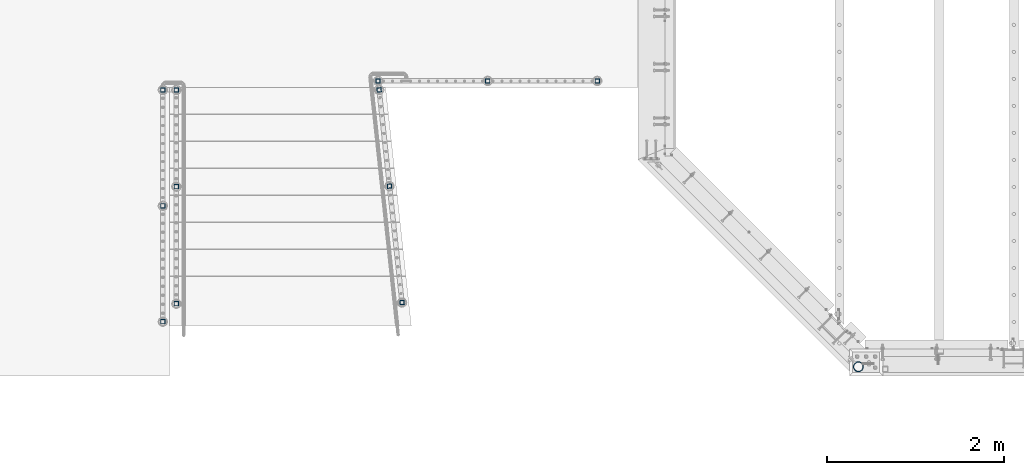
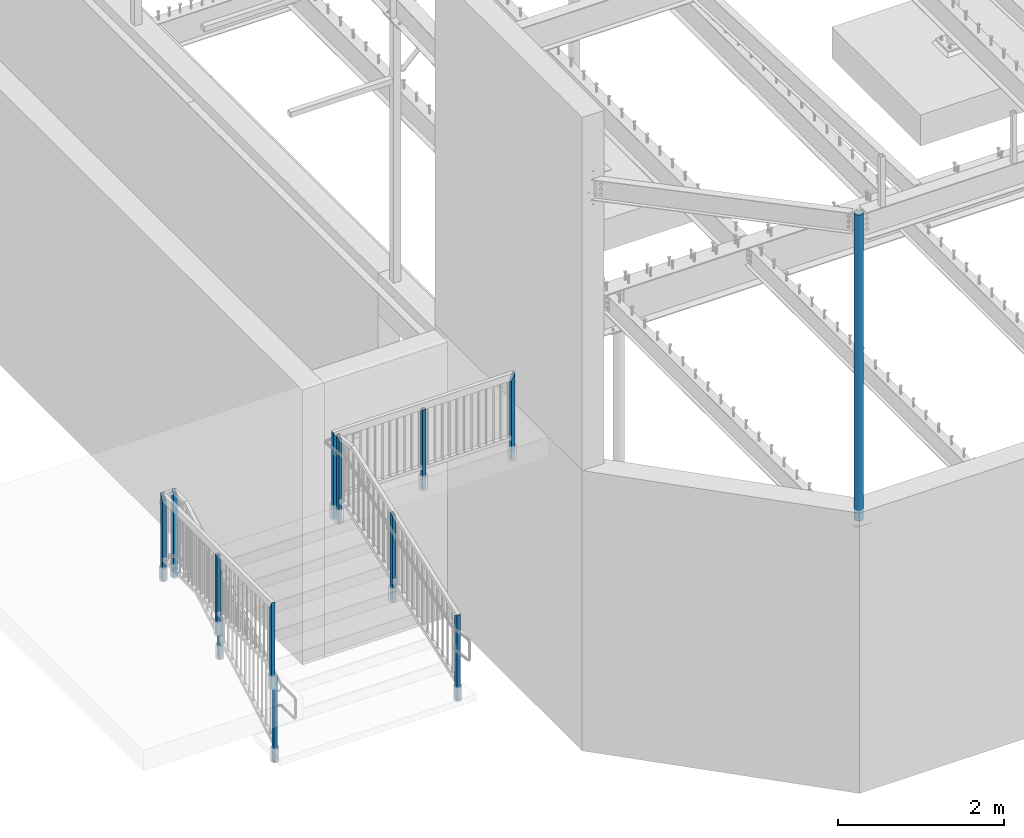
# One storey, part 120 of 975: 13 columns.
"""IFC2X3 building model written with IfcOpenShell, lengths in millimetres."""

import ifcopenshell
import ifcopenshell.guid

model = None  # the IFC model being written
_history = None  # IfcOwnerHistory: only IFC2X3 demands one
_inside = {}  # id of a spatial element -> (the spatial element, [elements in it])
_under = {}  # id of a project, library or spatial element -> (it, [spatial elements below it])
_declared = {}  # id of a project -> (the project, [libraries it declares])
_typed = {}  # id of a type object -> (the type object, [elements of that type])
_made_of = {}  # id of a material, layer set ... -> (it, [elements and type objects made of it])


def new_model(schema):
    """Start an empty IFC model of exactly this schema.

    Asked for "IFC4X3", IfcOpenShell would pick the latest addendum, in which some entities
    have other attributes; the version numbers below select the first issue.
    IFC2X3 requires an IfcOwnerHistory on every rooted entity: one is made here for all.
    """
    global model, _history
    if schema == "IFC4X3":
        model = ifcopenshell.file(schema_version=(4, 3, 0, 0))
    else:
        model = ifcopenshell.file(schema=schema)
    _inside.clear()
    _under.clear()
    _declared.clear()
    _typed.clear()
    _made_of.clear()
    _history = None
    if model.schema == "IFC2X3":
        org = make("IfcOrganization", Name="unknown")
        user = make(
            "IfcPersonAndOrganization",
            ThePerson=make("IfcPerson", FamilyName="unknown"),
            TheOrganization=org,
        )
        app = make(
            "IfcApplication",
            ApplicationDeveloper=org,
            Version="unknown",
            ApplicationFullName="unknown",
            ApplicationIdentifier="unknown",
        )
        _history = make(
            "IfcOwnerHistory",
            OwningUser=user,
            OwningApplication=app,
            ChangeAction="ADDED",
            CreationDate=0,
        )
    return model


def make(cls, **values):
    """One entity of the class cls with the attributes given. An attribute that is None is left unset."""
    return model.create_entity(
        cls, **{name: value for name, value in values.items() if value is not None}
    )


def rooted(cls, **values):
    """An entity with a GlobalId (a new one), such as an element, a storey or a relation."""
    return make(cls, GlobalId=ifcopenshell.guid.new(), OwnerHistory=_history, **values)


def si_unit(unit_type, name, prefix=None):
    """IfcSIUnit, for example si_unit("LENGTHUNIT", "METRE", prefix="MILLI")."""
    return make("IfcSIUnit", UnitType=unit_type, Prefix=prefix, Name=name)


def assignment(units):
    """IfcUnitAssignment: the units of a project."""
    return None if units is None else make("IfcUnitAssignment", Units=units)


def point(xyz):
    """IfcCartesianPoint."""
    return None if xyz is None else make("IfcCartesianPoint", Coordinates=xyz)


def direction(xyz):
    """IfcDirection."""
    return None if xyz is None else make("IfcDirection", DirectionRatios=xyz)


def frame(location, z_axis=None, x_axis=None):
    """IfcAxis2Placement3D, a coordinate frame: its origin and axes. An axis left out is left unset."""
    return make(
        "IfcAxis2Placement3D",
        Location=point(location),
        Axis=direction(z_axis),
        RefDirection=direction(x_axis),
    )


def origin_with_axes():
    """The frame at (0, 0, 0) with the z axis (0, 0, 1) and the x axis (1, 0, 0) written out."""
    return frame((0.0, 0.0, 0.0), z_axis=(0.0, 0.0, 1.0), x_axis=(1.0, 0.0, 0.0))


def place(relative_to, where):
    """IfcLocalPlacement: puts the frame where relative to a parent placement (None: the world)."""
    return make(
        "IfcLocalPlacement", PlacementRelTo=relative_to, RelativePlacement=where
    )


def context(
    kind, dimensions, precision=None, world=None, true_north=None, identifier=None
):
    """IfcGeometricRepresentationContext, for example the 3D "Model" context."""
    return make(
        "IfcGeometricRepresentationContext",
        ContextIdentifier=identifier,
        ContextType=kind,
        CoordinateSpaceDimension=dimensions,
        Precision=precision,
        WorldCoordinateSystem=world,
        TrueNorth=true_north,
    )


def subcontext(parent, identifier, kind, view, scale=None):
    """IfcGeometricRepresentationSubContext, for example "Body" below "Model"."""
    return make(
        "IfcGeometricRepresentationSubContext",
        ContextIdentifier=identifier,
        ContextType=kind,
        ParentContext=parent,
        TargetScale=scale,
        TargetView=view,
    )


def project(units=None, contexts=None):
    """IfcProject with its units and contexts."""
    return rooted(
        "IfcProject",
        Name="project",
        RepresentationContexts=contexts,
        UnitsInContext=assignment(units),
    )


def spatial(cls, under=None, at=None, **own):
    """A site, building, storey or space (cls), placed at a placement, below another one or the project."""
    s = rooted(cls, ObjectPlacement=at, **own)
    if under is not None:
        _under.setdefault(under.id(), (under, []))[1].append(s)
    return s


def faces_of(points, faces, orient=None, outer=None):
    """IfcFace entities. A face is a list of loops; a loop is a list of indices into points, from 0.

    orient and outer hold one flag for each loop. By default every Orientation is true, the
    first loop of a face is its IfcFaceOuterBound and the others are IfcFaceBound.
    """
    made = []
    for i, loops in enumerate(faces):
        bounds = []
        for j, loop in enumerate(loops):
            is_outer = j == 0 if outer is None else outer[i][j]
            bounds.append(
                make(
                    "IfcFaceOuterBound" if is_outer else "IfcFaceBound",
                    Bound=make("IfcPolyLoop", Polygon=[points[k] for k in loop]),
                    Orientation=True if orient is None else orient[i][j],
                )
            )
        made.append(make("IfcFace", Bounds=bounds))
    return made


def faceted_brep(points, faces, orient=None, outer=None, voids=None):
    """IfcFacetedBrep: a solid bounded by flat faces; with voids (closed shells), ...WithVoids."""
    shared = [point(p) for p in points]
    hull = make("IfcClosedShell", CfsFaces=faces_of(shared, faces, orient, outer))
    if voids is None:
        return make("IfcFacetedBrep", Outer=hull)
    return make(
        "IfcFacetedBrepWithVoids",
        Outer=hull,
        Voids=[
            make(cls, CfsFaces=faces_of(shared, fs, o, b)) for cls, fs, o, b in voids
        ],
    )


def shape(context_of_items, identifier, shape_type, items):
    """IfcShapeRepresentation: the items that make up one representation, for example the "Body"."""
    return make(
        "IfcShapeRepresentation",
        ContextOfItems=context_of_items,
        RepresentationIdentifier=identifier,
        RepresentationType=shape_type,
        Items=items,
    )


def material(Name=None, Category=None):
    """IfcMaterial."""
    return make("IfcMaterial", Name=Name, Category=Category)


def made_of(thing, what):
    """Note that an element or type object is made of a material, layer set ...; save() writes the relation."""
    if what is not None:
        _made_of.setdefault(what.id(), (what, []))[1].append(thing)
    return thing


def type_object(cls, material=None, **own):
    """A type object (cls), such as IfcWallType, which elements share."""
    return made_of(rooted(cls, **own), material)


def element(
    cls,
    number,
    at=None,
    inside=None,
    cuts=None,
    type_object=None,
    material=None,
    context=None,
    identifier="Body",
    shape_type=None,
    held_by="IfcProductDefinitionShape",
    body=None,
    shapes=None,
    **own,
):
    """One element of the class cls, such as IfcWall. Its Tag is "e" and its number.

    at: its placement. inside: the storey or other place that contains it. cuts: it is an
    opening in that element (IfcRelVoidsElement). A single representation is given by context,
    identifier, shape_type and body (its items); several are given by shapes. held_by: the class
    of the entity that holds the representations. save() writes the other relations.
    """
    e = rooted(cls, Tag="e%d" % number, ObjectPlacement=at, **own)
    if body is not None:
        shapes = [shape(context, identifier, shape_type, body)]
    if shapes is not None:
        e.Representation = make(held_by, Representations=shapes)
    if inside is not None:
        _inside.setdefault(inside.id(), (inside, []))[1].append(e)
    if cuts is not None:
        rooted(
            "IfcRelVoidsElement", RelatingBuildingElement=cuts, RelatedOpeningElement=e
        )
    if type_object is not None:
        _typed.setdefault(type_object.id(), (type_object, []))[1].append(e)
    return made_of(e, material)


def aggregate(whole, parts):
    """IfcRelAggregates: a whole, such as a stair, and the parts it consists of."""
    return rooted("IfcRelAggregates", RelatingObject=whole, RelatedObjects=parts)


def save(model, path):
    """Write the relations noted so far, then the file.

    IfcRelAggregates (storeys below a building ...), IfcRelContainedInSpatialStructure (elements
    in a storey), IfcRelDefinesByType, IfcRelAssociatesMaterial and IfcRelDeclares: one each for
    every whole, place, type object, material and project.
    """
    for whole, parts in _under.values():
        aggregate(whole, parts)
    for where, things in _inside.values():
        rooted(
            "IfcRelContainedInSpatialStructure",
            RelatedElements=things,
            RelatingStructure=where,
        )
    for kind, things in _typed.values():
        rooted("IfcRelDefinesByType", RelatedObjects=things, RelatingType=kind)
    for what, things in _made_of.values():
        rooted("IfcRelAssociatesMaterial", RelatedObjects=things, RelatingMaterial=what)
    for by, libraries in _declared.values():
        rooted("IfcRelDeclares", RelatingContext=by, RelatedDefinitions=libraries)
    model.write(path)


model = new_model("IFC2X3")

# Units and contexts
model_context = context("Model", 3, precision=1e-05, world=origin_with_axes())
body_context = subcontext(model_context, "Body", "Model", "MODEL_VIEW")
ifc_project = project(units=[si_unit("LENGTHUNIT", "METRE", prefix="MILLI"), si_unit("AREAUNIT", "SQUARE_METRE"), si_unit("VOLUMEUNIT", "CUBIC_METRE"), si_unit("MASSUNIT", "GRAM", prefix="KILO"), si_unit("TIMEUNIT", "SECOND"), si_unit("PLANEANGLEUNIT", "RADIAN"), si_unit("SOLIDANGLEUNIT", "STERADIAN"), si_unit("THERMODYNAMICTEMPERATUREUNIT", "DEGREE_CELSIUS"), si_unit("LUMINOUSINTENSITYUNIT", "LUMEN")], contexts=[model_context])

# Site, building, storey
site_placement = place(None, origin_with_axes())
site = spatial("IfcSite", under=ifc_project, at=site_placement, CompositionType="ELEMENT")
building_placement = place(site_placement, origin_with_axes())
building = spatial("IfcBuilding", under=site, at=building_placement, Name="Undefined", CompositionType="ELEMENT")
storey_placement = place(building_placement, origin_with_axes())
storey = spatial("IfcBuildingStorey", under=building, at=storey_placement, Name="Undefined", CompositionType="ELEMENT", Elevation=0.0)

# Columns
ifc_material_1 = material()
column_type_1 = type_object("IfcColumnType", Name="HSS2X2X.188_TUBES", PredefinedType="NOTDEFINED")
column_1_placement = place(storey_placement, frame((1558.92499396022, 3327.43642318416, 3911.60001649977), z_axis=(1.0, 0.0, 0.0), x_axis=(0.0, 0.0, 1.0)))
element("IfcColumn", 1, at=column_1_placement, inside=storey, type_object=column_type_1, material=ifc_material_1, Name="HANDRAIL", ObjectType="HSS2X2X.188_TUBES", context=body_context, shape_type="Brep", body=[
    faceted_brep([(0.0, 20.6374999999753, -20.6375000000298), (0.0, -20.6375000000153, -20.6375000000153), (1177.92497225151, -20.6375000000007, -20.6374999999875), (1177.92497102682, 20.6375000000371, -20.6374999999944), (0.0, -20.6374999999825, 20.6375000000335), (1260.47497075396, -20.6375000000335, 20.6375000000207), (0.0, 20.6375000000116, 20.6375000000189), (1260.47497199207, 20.6375000000007, 20.6375000000132), (0.0, 25.3999999999724, -25.4000000000342), (0.0, 25.400000000016, 25.4000000000196), (1269.99997196214, 25.4000000000015, 25.4000000000135), (1168.40000063294, 25.3999999999724, -25.4000000000342), (0.0, -25.399999999976, 25.4000000000378), (1269.99994272909, -25.3999999999614, 25.3999999999912), (0.0, -25.400000000016, -25.4000000000196), (1168.39999998263, -25.400000000016, -25.4000000000196)], [[[0, 1, 2, 3]], [[1, 4, 5, 2]], [[4, 6, 7, 5]], [[6, 0, 3, 7]], [[8, 9, 10, 11]], [[9, 12, 13, 10]], [[12, 14, 15, 13]], [[14, 8, 11, 15]], [[13, 15, 11, 10], [5, 7, 3, 2]], [[14, 12, 9, 8], [6, 4, 1, 0]]]),
])
column_2_placement = place(storey_placement, frame((322.695797111396, 3327.40039056697, 3911.60001649977), z_axis=(1.0, 0.0, 0.0), x_axis=(0.0, 0.0, 1.0)))
element("IfcColumn", 2, at=column_2_placement, inside=storey, type_object=column_type_1, material=ifc_material_1, Name="HANDRAIL", ObjectType="HSS2X2X.188_TUBES", context=body_context, shape_type="Brep", body=[
    faceted_brep([(0.0, 20.6374999999753, -20.6375000000298), (0.0, -20.6375000000153, -20.6375000000153), (1168.39997128085, -20.6374999999789, -20.637499999993), (1168.39997128085, 20.6375000000371, -20.6374999999939), (0.0, -20.6374999999825, 20.6375000000335), (1168.40000013214, -20.6375000000371, 20.6375000000189), (0.0, 20.6375000000116, 20.6375000000189), (1168.40000013214, 20.6374999999789, 20.637500000018), (0.0, 25.3999999999724, -25.4000000000342), (0.0, 25.400000000016, 25.4000000000196), (1168.40000346113, 25.399999999976, 25.4000000000215), (1168.40000063294, 25.3999999999724, -25.4000000000342), (0.0, -25.399999999976, 25.4000000000378), (1168.40000346113, -25.4000000000451, 25.4000000000201), (0.0, -25.400000000016, -25.4000000000196), (1168.39999998263, -25.400000000016, -25.4000000000196)], [[[0, 1, 2, 3]], [[1, 4, 5, 2]], [[4, 6, 7, 5]], [[6, 0, 3, 7]], [[8, 9, 10, 11]], [[9, 12, 13, 10]], [[12, 14, 15, 13]], [[14, 8, 11, 15]], [[13, 15, 11, 10], [5, 7, 3, 2]], [[14, 12, 9, 8], [6, 4, 1, 0]]]),
])
column_3_placement = place(storey_placement, frame((-913.533791529012, 3327.43681221011, 3911.60001649977), z_axis=(1.0, 0.0, 0.0), x_axis=(0.0, 0.0, 1.0)))
element("IfcColumn", 3, at=column_3_placement, inside=storey, type_object=column_type_1, material=ifc_material_1, Name="HANDRAIL", ObjectType="HSS2X2X.188_TUBES", context=body_context, shape_type="Brep", body=[
    faceted_brep([(0.0, 20.6374999999753, -20.6375000000298), (0.0, -20.6375000000153, -20.6375000000153), (1260.4757554614, -20.637500000013, -20.6375), (1260.47574254232, 20.6374999999871, -20.6375), (0.0, -20.6374999999825, 20.6375000000335), (1177.92576829022, -20.6375000000126, 20.6375), (0.0, 20.6375000000116, 20.6375000000189), (1177.92575537115, 20.6374999999875, 20.6375), (0.0, 25.3999999999724, -25.4000000000342), (0.0, 25.400000000016, 25.4000000000196), (1168.40075536074, 25.3999999999878, 25.4), (1270.00073957141, 25.3999999999864, -25.4), (0.0, -25.399999999976, 25.4000000000378), (1168.40077126113, -25.4000000000124, 25.4), (0.0, -25.400000000016, -25.4000000000196), (1270.00075547181, -25.4000000000133, -25.4)], [[[0, 1, 2, 3]], [[1, 4, 5, 2]], [[4, 6, 7, 5]], [[6, 0, 3, 7]], [[8, 9, 10, 11]], [[9, 12, 13, 10]], [[12, 14, 15, 13]], [[14, 8, 11, 15]], [[13, 15, 11, 10], [5, 7, 3, 2]], [[14, 12, 9, 8], [6, 4, 1, 0]]]),
])
column_4_placement = place(storey_placement, frame((-3343.2749985941, 3225.80035284919, 3911.60001649977), z_axis=(0.0, 1.0, 0.0), x_axis=(0.0, 0.0, 1.0)))
element("IfcColumn", 4, at=column_4_placement, inside=storey, type_object=column_type_1, material=ifc_material_1, Name="HANDRAIL", ObjectType="HSS2X2X.188_TUBES", context=body_context, shape_type="Brep", body=[
    faceted_brep([(0.0, 20.6374999999753, -20.6375000000298), (0.0, -20.6375000000153, -20.6375000000153), (1177.92497225151, -20.6375000000007, -20.6374999999875), (1177.92497102682, 20.6375000000371, -20.6374999999944), (0.0, -20.6374999999825, 20.6375000000335), (1260.47497075396, -20.6375000000335, 20.6375000000207), (0.0, 20.6375000000116, 20.6375000000189), (1260.47497199207, 20.6375000000007, 20.6375000000132), (0.0, 25.3999999999724, -25.4000000000342), (0.0, 25.400000000016, 25.4000000000196), (1269.99997196214, 25.4000000000015, 25.4000000000135), (1168.40000063294, 25.3999999999724, -25.4000000000342), (0.0, -25.399999999976, 25.4000000000378), (1269.99994272909, -25.3999999999614, 25.3999999999912), (0.0, -25.400000000016, -25.4000000000196), (1168.39999998263, -25.400000000016, -25.4000000000196)], [[[0, 1, 2, 3]], [[1, 4, 5, 2]], [[4, 6, 7, 5]], [[6, 0, 3, 7]], [[8, 9, 10, 11]], [[9, 12, 13, 10]], [[12, 14, 15, 13]], [[14, 8, 11, 15]], [[13, 15, 11, 10], [5, 7, 3, 2]], [[14, 12, 9, 8], [6, 4, 1, 0]]]),
])
column_5_placement = place(storey_placement, frame((-3343.2749985941, 1917.70035254451, 3911.60001649977), z_axis=(0.0, 1.0, 0.0), x_axis=(0.0, 0.0, 1.0)))
element("IfcColumn", 5, at=column_5_placement, inside=storey, type_object=column_type_1, material=ifc_material_1, Name="HANDRAIL", ObjectType="HSS2X2X.188_TUBES", context=body_context, shape_type="Brep", body=[
    faceted_brep([(0.0, 20.6374999999753, -20.6375000000298), (0.0, -20.6375000000153, -20.6375000000153), (1168.39997128085, -20.6374999999789, -20.637499999993), (1168.39997128085, 20.6375000000371, -20.6374999999939), (0.0, -20.6374999999825, 20.6375000000335), (1168.40000013214, -20.6375000000371, 20.6375000000189), (0.0, 20.6375000000116, 20.6375000000189), (1168.40000013214, 20.6374999999789, 20.637500000018), (0.0, 25.3999999999724, -25.4000000000342), (0.0, 25.400000000016, 25.4000000000196), (1168.40000346113, 25.399999999976, 25.4000000000215), (1168.40000063294, 25.3999999999724, -25.4000000000342), (0.0, -25.399999999976, 25.4000000000378), (1168.40000346113, -25.4000000000451, 25.4000000000201), (0.0, -25.400000000016, -25.4000000000196), (1168.39999998263, -25.400000000016, -25.4000000000196)], [[[0, 1, 2, 3]], [[1, 4, 5, 2]], [[4, 6, 7, 5]], [[6, 0, 3, 7]], [[8, 9, 10, 11]], [[9, 12, 13, 10]], [[12, 14, 15, 13]], [[14, 8, 11, 15]], [[13, 15, 11, 10], [5, 7, 3, 2]], [[14, 12, 9, 8], [6, 4, 1, 0]]]),
])
column_6_placement = place(storey_placement, frame((-3343.2749985941, 609.600352239831, 3911.60002239251), z_axis=(0.0, 1.0, 0.0), x_axis=(0.0, 0.0, 1.0)))
element("IfcColumn", 6, at=column_6_placement, inside=storey, type_object=column_type_1, material=ifc_material_1, Name="HANDRAIL", ObjectType="HSS2X2X.188_TUBES", context=body_context, shape_type="Brep", body=[
    faceted_brep([(0.0, 20.6374999999753, -20.6375000000298), (0.0, -20.6375000000153, -20.6375000000153), (1260.4749795328, -20.6374999994405, -20.6375), (1260.47498063661, 20.6375000005683, -20.6375000001867), (0.0, -20.6374999999825, 20.6375000000335), (1177.92498039691, -20.6374999995278, 20.6374999998725), (0.0, 20.6375000000116, 20.6375000000189), (1177.92498168426, 20.637500000521, 20.6375), (0.0, 25.3999999999724, -25.4000000000342), (0.0, 25.400000000016, 25.4000000000196), (1168.40000346113, 25.399999999976, 25.4000000000215), (1269.99998066427, 25.4000000005799, -25.4000000001936), (0.0, -25.399999999976, 25.4000000000378), (1168.40000346113, -25.4000000000451, 25.4000000000201), (0.0, -25.400000000016, -25.4000000000196), (1269.99993851146, -25.3999999999978, -25.3999999999983)], [[[0, 1, 2, 3]], [[1, 4, 5, 2]], [[4, 6, 7, 5]], [[6, 0, 3, 7]], [[8, 9, 10, 11]], [[9, 12, 13, 10]], [[12, 14, 15, 13]], [[14, 8, 11, 15]], [[13, 15, 11, 10], [5, 7, 3, 2]], [[14, 12, 9, 8], [6, 4, 1, 0]]]),
])
column_7_placement = place(storey_placement, frame((-785.534411542738, 2139.88991820161, 3378.20002478374), z_axis=(-0.107163682972125, 0.994241391741387, -1.51279482452082e-08), x_axis=(0.0, 0.0, 1.0)))
element("IfcColumn", 7, at=column_7_placement, inside=storey, type_object=column_type_1, material=ifc_material_1, Name="HANDRAIL", ObjectType="HSS2X2X.188_TUBES", context=body_context, shape_type="Brep", body=[
    faceted_brep([(0.0, 20.6374999999753, -20.6375000000298), (0.0, -20.6375000000153, -20.6375000000153), (1258.4167483821, -20.637500000004, -20.6375000001622), (1258.41674839413, 20.6374999999963, -20.6375000001531), (0.0, -20.6374999999825, 20.6375000000335), (1282.493832399, -20.6375000000046, 20.6374999998293), (0.0, 20.6375000000116, 20.6375000000189), (1282.49383241103, 20.637499999996, 20.6374999998379), (0.0, 25.3999999999724, -25.4000000000342), (0.0, 25.400000000016, 25.4000000000196), (1285.2719574913, 25.399999999996, 25.3999999998387), (1255.63862331665, 25.3999999999963, -25.4000000001511), (0.0, -25.399999999976, 25.4000000000378), (1285.27195747649, -25.4000000000044, 25.3999999998277), (0.0, -25.400000000016, -25.4000000000196), (1255.63862330184, -25.4000000000041, -25.4000000001624)], [[[0, 1, 2, 3]], [[1, 4, 5, 2]], [[4, 6, 7, 5]], [[6, 0, 3, 7]], [[8, 9, 10, 11]], [[9, 12, 13, 10]], [[12, 14, 15, 13]], [[14, 8, 11, 15]], [[13, 15, 11, 10], [5, 7, 3, 2]], [[14, 12, 9, 8], [6, 4, 1, 0]]]),
])
column_8_placement = place(storey_placement, frame((-902.57861743711, 3225.80035230631, 3911.59996494345), z_axis=(-0.107163682972125, 0.994241391741387, -1.51279482452082e-08), x_axis=(0.0, 0.0, 1.0)))
element("IfcColumn", 8, at=column_8_placement, inside=storey, type_object=column_type_1, material=ifc_material_1, Name="HANDRAIL", ObjectType="HSS2X2X.188_TUBES", context=body_context, shape_type="Brep", body=[
    faceted_brep([(0.0, 20.6374999999753, -20.6375000000298), (0.0, -20.6375000000153, -20.6375000000153), (1223.96249999353, -20.6374999999753, -20.6375000000226), (1223.96250596358, 20.6374999999838, -20.6375000001476), (0.0, -20.6374999999825, 20.6375000000335), (1265.23750372074, -20.6375000000173, 20.6374999998329), (0.0, 20.6375000000116, 20.6375000000189), (1265.23749994241, 20.6374999999862, 20.6375000000153), (0.0, 25.3999999999724, -25.4000000000342), (0.0, 25.400000000016, 25.4000000000196), (1269.99997196214, 25.4000000000015, 25.4000000000135), (1219.2, 25.3999999999814, -25.3999999999614), (0.0, -25.399999999976, 25.4000000000378), (1270.00000346195, -25.4000000000175, 25.3999999998309), (0.0, -25.400000000016, -25.4000000000196), (1219.2, -25.399999999996, -25.4000000000378)], [[[0, 1, 2, 3]], [[1, 4, 5, 2]], [[4, 6, 7, 5]], [[6, 0, 3, 7]], [[8, 9, 10, 11]], [[9, 12, 13, 10]], [[12, 14, 15, 13]], [[14, 8, 11, 15]], [[13, 15, 11, 10], [5, 7, 3, 2]], [[14, 12, 9, 8], [6, 4, 1, 0]]]),
])
column_9_placement = place(storey_placement, frame((-643.992578658733, 826.6958816702, 2666.99998821452), z_axis=(-0.107163682972125, 0.994241391741387, -1.51279482452082e-08), x_axis=(0.0, 0.0, 1.0)))
element("IfcColumn", 9, at=column_9_placement, inside=storey, type_object=column_type_1, material=ifc_material_1, Name="HANDRAIL", ObjectType="HSS2X2X.188_TUBES", context=body_context, shape_type="Brep", body=[
    faceted_brep([(0.0, 20.6374999999753, -20.6375000000298), (0.0, -20.6375000000153, -20.6375000000153), (1252.44789495893, -20.6374999999883, -20.6375000000174), (1252.44789497096, 20.637500000011, -20.6375000000177), (0.0, -20.6374999999825, 20.6375000000335), (1228.74075973061, -20.6374999999883, 20.6374999999824), (0.0, 20.6375000000116, 20.6375000000189), (1228.74075974264, 20.6375000000111, 20.6374999999821), (0.0, 25.3999999999724, -25.4000000000342), (0.0, 25.400000000016, 25.4000000000196), (1226.00532106384, 25.4000000000111, 25.399999999982), (1255.18333365254, 25.4000000000109, -25.4000000000176), (0.0, -25.399999999976, 25.4000000000378), (1226.00532104903, -25.3999999999882, 25.3999999999824), (0.0, -25.400000000016, -25.4000000000196), (1255.18333363773, -25.3999999999884, -25.4000000000173)], [[[0, 1, 2, 3]], [[1, 4, 5, 2]], [[4, 6, 7, 5]], [[6, 0, 3, 7]], [[8, 9, 10, 11]], [[9, 12, 13, 10]], [[12, 14, 15, 13]], [[14, 8, 11, 15]], [[13, 15, 11, 10], [5, 7, 3, 2]], [[14, 12, 9, 8], [6, 4, 1, 0]]]),
])
column_10_placement = place(storey_placement, frame((-3190.87499858123, 2133.60036285013, 3378.20002478374), z_axis=(0.0, 1.0, 0.0), x_axis=(0.0, 0.0, 1.0)))
element("IfcColumn", 10, at=column_10_placement, inside=storey, type_object=column_type_1, material=ifc_material_1, Name="HANDRAIL", ObjectType="HSS2X2X.188_TUBES", context=body_context, shape_type="Brep", body=[
    faceted_brep([(0.0, 20.6374999999753, -20.6375000000298), (0.0, -20.6375000000153, -20.6375000000153), (1258.4167483821, -20.637500000004, -20.6375000001622), (1258.41674839413, 20.6374999999963, -20.6375000001531), (0.0, -20.6374999999825, 20.6375000000335), (1282.493832399, -20.6375000000046, 20.6374999998293), (0.0, 20.6375000000116, 20.6375000000189), (1282.49383241103, 20.637499999996, 20.6374999998379), (0.0, 25.3999999999724, -25.4000000000342), (0.0, 25.400000000016, 25.4000000000196), (1285.2719574913, 25.399999999996, 25.3999999998387), (1255.63862331665, 25.3999999999963, -25.4000000001511), (0.0, -25.399999999976, 25.4000000000378), (1285.27195747649, -25.4000000000044, 25.3999999998277), (0.0, -25.400000000016, -25.4000000000196), (1255.63862330184, -25.4000000000041, -25.4000000001624)], [[[0, 1, 2, 3]], [[1, 4, 5, 2]], [[4, 6, 7, 5]], [[6, 0, 3, 7]], [[8, 9, 10, 11]], [[9, 12, 13, 10]], [[12, 14, 15, 13]], [[14, 8, 11, 15]], [[13, 15, 11, 10], [5, 7, 3, 2]], [[14, 12, 9, 8], [6, 4, 1, 0]]]),
])
column_11_placement = place(storey_placement, frame((-3190.87499858123, 3225.80035223983, 3911.59996494345), z_axis=(0.0, 1.0, 0.0), x_axis=(0.0, 0.0, 1.0)))
element("IfcColumn", 11, at=column_11_placement, inside=storey, type_object=column_type_1, material=ifc_material_1, Name="HANDRAIL", ObjectType="HSS2X2X.188_TUBES", context=body_context, shape_type="Brep", body=[
    faceted_brep([(0.0, 20.6374999999753, -20.6375000000298), (0.0, -20.6375000000153, -20.6375000000153), (1223.96249999353, -20.6374999999753, -20.6375000000226), (1223.96250596358, 20.6374999999838, -20.6375000001476), (0.0, -20.6374999999825, 20.6375000000335), (1265.23750372074, -20.6375000000173, 20.6374999998329), (0.0, 20.6375000000116, 20.6375000000189), (1265.23749994241, 20.6374999999862, 20.6375000000153), (0.0, 25.3999999999724, -25.4000000000342), (0.0, 25.400000000016, 25.4000000000196), (1269.99997196214, 25.4000000000015, 25.4000000000135), (1219.2, 25.3999999999814, -25.3999999999614), (0.0, -25.399999999976, 25.4000000000378), (1270.00000346195, -25.4000000000175, 25.3999999998309), (0.0, -25.400000000016, -25.4000000000196), (1219.2, -25.399999999996, -25.4000000000378)], [[[0, 1, 2, 3]], [[1, 4, 5, 2]], [[4, 6, 7, 5]], [[6, 0, 3, 7]], [[8, 9, 10, 11]], [[9, 12, 13, 10]], [[12, 14, 15, 13]], [[14, 8, 11, 15]], [[13, 15, 11, 10], [5, 7, 3, 2]], [[14, 12, 9, 8], [6, 4, 1, 0]]]),
])
column_12_placement = place(storey_placement, frame((-3190.87499858123, 812.800352239827, 2666.99998821452), z_axis=(0.0, 1.0, 0.0), x_axis=(0.0, 0.0, 1.0)))
element("IfcColumn", 12, at=column_12_placement, inside=storey, type_object=column_type_1, material=ifc_material_1, Name="HANDRAIL", ObjectType="HSS2X2X.188_TUBES", context=body_context, shape_type="Brep", body=[
    faceted_brep([(0.0, 20.6374999999753, -20.6375000000298), (0.0, -20.6375000000153, -20.6375000000153), (1252.44789495893, -20.6374999999883, -20.6375000000174), (1252.44789497096, 20.637500000011, -20.6375000000177), (0.0, -20.6374999999825, 20.6375000000335), (1228.74075973061, -20.6374999999883, 20.6374999999824), (0.0, 20.6375000000116, 20.6375000000189), (1228.74075974264, 20.6375000000111, 20.6374999999821), (0.0, 25.3999999999724, -25.4000000000342), (0.0, 25.400000000016, 25.4000000000196), (1226.00532106384, 25.4000000000111, 25.399999999982), (1255.18333365254, 25.4000000000109, -25.4000000000176), (0.0, -25.399999999976, 25.4000000000378), (1226.00532104903, -25.3999999999882, 25.3999999999824), (0.0, -25.400000000016, -25.4000000000196), (1255.18333363773, -25.3999999999884, -25.4000000000173)], [[[0, 1, 2, 3]], [[1, 4, 5, 2]], [[4, 6, 7, 5]], [[6, 0, 3, 7]], [[8, 9, 10, 11]], [[9, 12, 13, 10]], [[12, 14, 15, 13]], [[14, 8, 11, 15]], [[13, 15, 11, 10], [5, 7, 3, 2]], [[14, 12, 9, 8], [6, 4, 1, 0]]]),
])
ifc_material_2 = material(Name="STEEL/A53")
column_type_2 = type_object("IfcColumnType", Name="PIPE4STD", PredefinedType="NOTDEFINED")
column_13_placement = place(storey_placement, frame((4505.325, 101.6, 3937.0), z_axis=(0.0, 1.0, 0.0), x_axis=(0.0, 0.0, 1.0)))
element("IfcColumn", 13, at=column_13_placement, inside=storey, type_object=column_type_2, material=ifc_material_2, Name="COLUMN", ObjectType="PIPE4STD", context=body_context, shape_type="Brep", body=[
    faceted_brep([(19.0500000000025, -51.1301999999996, 0.0), (19.0500000000025, -48.6277098894743, 15.8001007257917), (4512.28317758515, -48.6277098894743, 15.8001007257899), (4512.28317758515, -51.1301999999996, 0.0), (19.0500000000025, -41.3652007257897, 30.0535775067656), (4512.28317758515, -41.3652007257897, 30.0535775067646), (19.0500000000025, -30.0535775067647, 41.3652007257915), (4512.28317758515, -30.0535775067647, 41.3652007257899), (19.0500000000025, -15.8001007257899, 48.6277098894752), (4512.28317758515, -15.8001007257899, 48.6277098894745), (19.0500000000025, 0.0, 51.1301999999996), (4512.28317758515, 0.0, 51.1302), (19.0500000000025, 15.8001007257899, 48.6277098894752), (4512.28317758515, 15.8001007257899, 48.6277098894745), (19.0500000000025, 30.0535775067647, 41.3652007257915), (4512.28317758515, 30.0535775067647, 41.3652007257899), (19.0500000000025, 41.3652007257897, 30.0535775067656), (4512.28317758515, 41.3652007257897, 30.0535775067646), (19.0500000000025, 48.6277098894743, 15.8001007257917), (4512.28317758515, 48.6277098894743, 15.8001007257899), (19.0500000000025, 51.1301999999996, 0.0), (4512.28317758515, 51.1301999999996, 0.0), (19.0500000000025, 48.6277098894743, -15.8001007257917), (4512.28317758515, 48.6277098894743, -15.8001007257899), (19.0500000000025, 41.3652007257897, -30.0535775067656), (4512.28317758515, 41.3652007257897, -30.0535775067646), (19.0500000000025, 30.0535775067647, -41.3652007257915), (4512.28317758515, 30.0535775067647, -41.3652007257899), (19.0500000000025, 15.8001007257899, -48.6277098894752), (4512.28317758515, 15.8001007257899, -48.6277098894745), (19.0500000000025, 0.0, -51.1301999999996), (4512.28317758515, 0.0, -51.1302), (19.0500000000025, -15.8001007257899, -48.6277098894752), (4512.28317758515, -15.8001007257899, -48.6277098894745), (19.0500000000025, -30.0535775067647, -41.3652007257915), (4512.28317758515, -30.0535775067647, -41.3652007257899), (19.0500000000025, -41.3652007257897, -30.0535775067656), (4512.28317758515, -41.3652007257897, -30.0535775067646), (19.0500000000025, -48.6277098894743, -15.8001007257917), (4512.28317758515, -48.6277098894743, -15.8001007257899), (19.0500000000025, -57.1499999999996, 0.0), (19.0500000000025, -54.3528799062678, -17.6603212285299), (4512.28317758515, -54.3528799062678, -17.6603212285283), (4512.28317758515, -57.1499999999996, 0.0), (19.0500000000025, -46.2353212285279, -33.5919271685161), (4512.28317758515, -46.2353212285279, -33.5919271685148), (19.0500000000025, -33.5919271685152, -46.235321228527), (4512.28317758515, -33.5919271685152, -46.2353212285282), (19.0500000000025, -17.6603212285281, -54.3528799062697), (4512.28317758515, -17.6603212285281, -54.352879906268), (19.0500000000025, 0.0, -57.1500000000015), (4512.28317758515, 0.0, -57.15), (19.0500000000025, 17.6603212285281, -54.3528799062697), (4512.28317758515, 17.6603212285281, -54.352879906268), (19.0500000000025, 33.5919271685152, -46.235321228527), (4512.28317758515, 33.5919271685152, -46.2353212285282), (19.0500000000025, 46.2353212285279, -33.5919271685161), (4512.28317758515, 46.2353212285279, -33.5919271685148), (19.0500000000025, 54.3528799062678, -17.6603212285299), (4512.28317758515, 54.3528799062678, -17.6603212285282), (19.0500000000025, 57.1499999999996, 0.0), (4512.28317758515, 57.1499999999996, 0.0), (19.0500000000025, 54.3528799062678, 17.6603212285299), (4512.28317758515, 54.3528799062678, 17.6603212285282), (19.0500000000025, 46.2353212285279, 33.5919271685161), (4512.28317758515, 46.2353212285279, 33.5919271685148), (19.0500000000025, 33.5919271685152, 46.235321228527), (4512.28317758515, 33.5919271685152, 46.2353212285282), (19.0500000000025, 17.6603212285281, 54.3528799062697), (4512.28317758515, 17.6603212285281, 54.352879906268), (19.0500000000025, 0.0, 57.1500000000015), (4512.28317758515, 0.0, 57.15), (19.0500000000025, -17.6603212285281, 54.3528799062697), (4512.28317758515, -17.6603212285281, 54.352879906268), (19.0500000000025, -33.5919271685152, 46.235321228527), (4512.28317758515, -33.5919271685152, 46.2353212285282), (19.0500000000025, -46.2353212285279, 33.5919271685161), (4512.28317758515, -46.2353212285279, 33.5919271685148), (19.0500000000025, -54.3528799062678, 17.6603212285299), (4512.28317758515, -54.3528799062678, 17.6603212285282)], [[[0, 1, 2, 3]], [[1, 4, 5, 2]], [[4, 6, 7, 5]], [[6, 8, 9, 7]], [[8, 10, 11, 9]], [[10, 12, 13, 11]], [[12, 14, 15, 13]], [[14, 16, 17, 15]], [[16, 18, 19, 17]], [[18, 20, 21, 19]], [[20, 22, 23, 21]], [[22, 24, 25, 23]], [[24, 26, 27, 25]], [[26, 28, 29, 27]], [[28, 30, 31, 29]], [[30, 32, 33, 31]], [[32, 34, 35, 33]], [[34, 36, 37, 35]], [[36, 38, 39, 37]], [[38, 0, 3, 39]], [[40, 41, 42, 43]], [[41, 44, 45, 42]], [[44, 46, 47, 45]], [[46, 48, 49, 47]], [[48, 50, 51, 49]], [[50, 52, 53, 51]], [[52, 54, 55, 53]], [[54, 56, 57, 55]], [[56, 58, 59, 57]], [[58, 60, 61, 59]], [[60, 62, 63, 61]], [[62, 64, 65, 63]], [[64, 66, 67, 65]], [[66, 68, 69, 67]], [[68, 70, 71, 69]], [[70, 72, 73, 71]], [[72, 74, 75, 73]], [[74, 76, 77, 75]], [[76, 78, 79, 77]], [[78, 40, 43, 79]], [[45, 47, 49, 51, 53, 55, 57, 59, 61, 63, 65, 67, 69, 71, 73, 75, 77, 79, 43, 42], [5, 7, 9, 11, 13, 15, 17, 19, 21, 23, 25, 27, 29, 31, 33, 35, 37, 39, 3, 2]], [[78, 76, 74, 72, 70, 68, 66, 64, 62, 60, 58, 56, 54, 52, 50, 48, 46, 44, 41, 40], [38, 36, 34, 32, 30, 28, 26, 24, 22, 20, 18, 16, 14, 12, 10, 8, 6, 4, 1, 0]]]),
])

save(model, "model.ifc")
